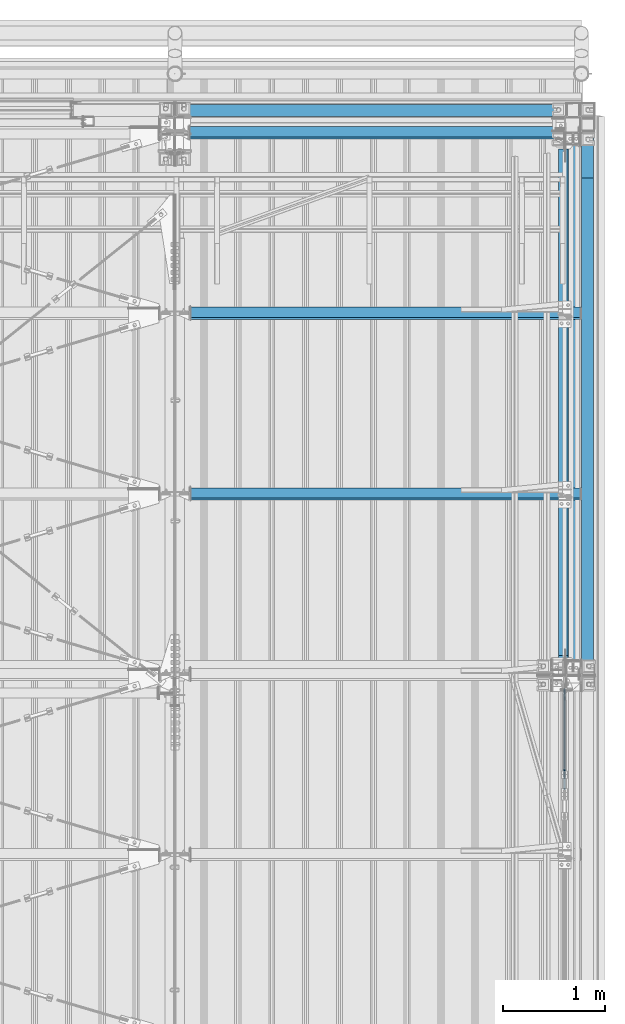
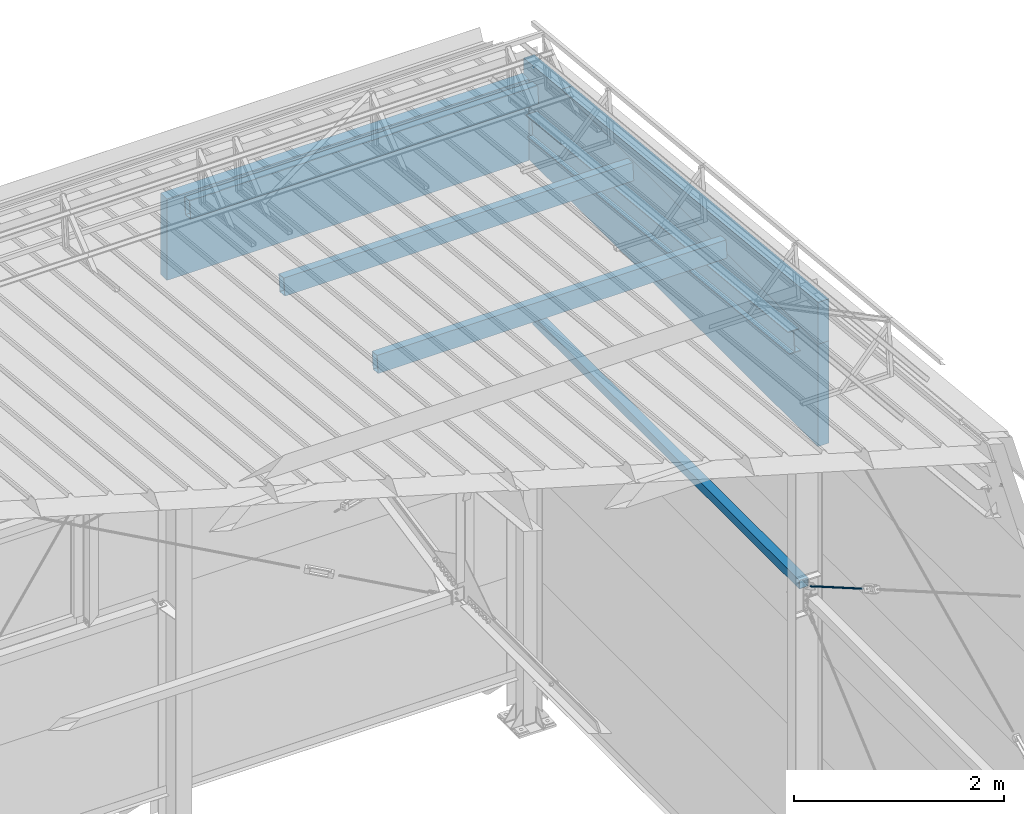
# One storey, part 289 of 709: 8 beams, 1 member, 1 opening, 9 elements without a shape of their own.
"""IFC4 building model written with IfcOpenShell, lengths in millimetres."""

from ifc_helpers import new_model, si_unit, direction, frame, origin_with_axes, place, context, subcontext, project, spatial, line, indexed_curve, outline, extrude, polygons, material, element, aggregate, save


model = new_model("IFC4")

# Units and contexts
model_context = context("Model", 3, precision=0.2, world=origin_with_axes(), true_north=direction((0.0, 1.0)))
body_context = subcontext(model_context, "Body", "Model", "MODEL_VIEW")
reference_context = subcontext(model_context, "Reference", "Model", "MODEL_VIEW")
ifc_project = project(units=[si_unit("LENGTHUNIT", "METRE", prefix="MILLI"), si_unit("AREAUNIT", "SQUARE_METRE"), si_unit("VOLUMEUNIT", "CUBIC_METRE"), si_unit("MASSUNIT", "GRAM", prefix="KILO"), si_unit("TIMEUNIT", "SECOND"), si_unit("PLANEANGLEUNIT", "RADIAN"), si_unit("SOLIDANGLEUNIT", "STERADIAN"), si_unit("THERMODYNAMICTEMPERATUREUNIT", "DEGREE_CELSIUS"), si_unit("LUMINOUSINTENSITYUNIT", "LUMEN")], contexts=[model_context])

# Site, building, storey
site_placement = place(None, origin_with_axes())
site = spatial("IfcSite", under=ifc_project, at=site_placement, CompositionType="ELEMENT")
building_placement = place(site_placement, origin_with_axes())
building = spatial("IfcBuilding", under=site, at=building_placement, Name="Undefined", CompositionType="ELEMENT")
storey_placement = place(building_placement, origin_with_axes())
storey = spatial("IfcBuildingStorey", under=building, at=storey_placement, Name="Undefined", CompositionType="ELEMENT", Elevation=0.0)

# Assembly, beam
assembly_1_placement = place(storey_placement, frame((49837.5, 21654.0, 6929.907), z_axis=(-1.0, 0.0, 0.0), x_axis=(0.0, -0.9950371902, 0.099503719)))
assembly_1 = element("IfcElementAssembly", 1, at=assembly_1_placement, inside=storey)
ifc_material_1 = material(Name="C255-4", Category="STEEL")
beam_1_placement = place(assembly_1_placement, origin_with_axes())
beam_1 = element("IfcBeam", 2, at=beam_1_placement, material=ifc_material_1, ObjectType="451", context=body_context, shape_type="Tessellation", body=[
    polygons([(-15.12818, -124.0, 62.0), (-15.12818, -116.0, 62.0), (-15.12818, -116.0, 2.5), (-15.12818, 116.0, 2.5), (-15.12818, 116.0, 62.0), (-15.12818, 124.0, 62.0), (-15.12818, 124.0, -62.0), (-15.12818, 116.0, -62.0), (-15.12818, 116.0, -2.5), (-15.12818, -116.0, -2.5), (-15.12818, -116.0, -62.0), (-15.12818, -124.0, -62.0), (4996.83432, 124.0, 62.0), (4996.83432, 124.0, -62.0), (4996.83432, 116.0, -62.0), (4996.83432, 116.0, -2.5), (4996.83432, -116.0, -2.5), (4996.83432, -116.0, -62.0), (4996.83432, -124.0, -62.0), (4996.83432, -124.0, 62.0), (4996.83432, -116.0, 62.0), (4996.83432, -116.0, 2.5), (4996.83432, 116.0, 2.5), (4996.83432, 116.0, 62.0)], [[[1, 2, 3, 4, 5, 6, 7, 8, 9, 10, 11, 12]], [[7, 6, 13, 14]], [[8, 7, 14, 15]], [[9, 8, 15, 16]], [[10, 9, 16, 17]], [[11, 10, 17, 18]], [[12, 11, 18, 19]], [[1, 12, 19, 20]], [[2, 1, 20, 21]], [[3, 2, 21, 22]], [[4, 3, 22, 23]], [[5, 4, 23, 24]], [[6, 5, 24, 13]], [[23, 22, 21, 20, 19, 18, 17, 16, 15, 14, 13, 24]]], closed=True),
])
aggregate(assembly_1, [beam_1])

# Assembly, member, voiding feature
assembly_2_placement = place(storey_placement, frame((49835.0, 15212.89749, 5439.71077), z_axis=(1.0, 0.0, 0.0), x_axis=(0.0, 0.866144648, -0.499793406)))
assembly_2 = element("IfcElementAssembly", 3, at=assembly_2_placement, inside=storey)
ifc_material_2 = material(Name="C355-5", Category="STEEL")
member_placement = place(assembly_2_placement, origin_with_axes())
member = element("IfcMember", 4, at=member_placement, material=ifc_material_2, ObjectType="515", context=body_context, shape_type="Tessellation", body=[
    polygons([(1330.0, -5.0, 8.66025), (1330.0, -7.07107, 7.07107), (1330.0, -8.66025, 5.0), (1330.0, -9.65926, 2.58819), (1330.0, -10.0, 0.0), (1330.0, -9.65926, -2.58819), (1330.0, -8.66025, -5.0), (1330.0, -7.07107, -7.07107), (1330.0, -5.0, -8.66025), (1330.0, -2.58819, -9.65926), (1330.0, 0.0, -10.0), (1330.0, 2.58819, -9.65926), (1330.0, 5.0, -8.66025), (1330.0, 7.07107, -7.07107), (1330.0, 8.66025, -5.0), (1330.0, 9.65926, -2.58819), (1330.0, 10.0, 0.0), (1330.0, 9.65926, 2.58819), (1330.0, 8.66025, 5.0), (1330.0, 7.07107, 7.07107), (1330.0, 5.0, 8.66025), (1330.0, 2.58819, 9.65926), (1330.0, 0.0, 10.0), (1330.0, -2.58819, 9.65926), (190.0, 10.0, 0.0), (190.0, 9.65926, 2.58819), (190.0, 8.66025, 5.0), (190.0, 7.07107, 7.07107), (190.0, 5.0, 8.66025), (190.0, 2.58819, 9.65926), (190.0, 0.0, 10.0), (190.0, -2.58819, 9.65926), (190.0, -5.0, 8.66025), (190.0, -7.07107, 7.07107), (190.0, -8.66025, 5.0), (190.0, -9.65926, 2.58819), (190.0, -10.0, 0.0), (190.0, -9.65926, -2.58819), (190.0, -8.66025, -5.0), (190.0, -7.07107, -7.07107), (190.0, -5.0, -8.66025), (190.0, -2.58819, -9.65926), (190.0, 0.0, -10.0), (190.0, 2.58819, -9.65926), (190.0, 5.0, -8.66025), (190.0, 7.07107, -7.07107), (190.0, 8.66025, -5.0), (190.0, 9.65926, -2.58819), (10.0, 7.36122, 4.25), (190.0, 7.36122, 4.25), (190.0, 8.21037, 2.19996), (10.0, 8.21037, 2.19996), (10.0, 6.01041, 6.01041), (190.0, 6.01041, 6.01041), (10.0, 4.25, 7.36122), (190.0, 4.25, 7.36122), (10.0, 2.19996, 8.21037), (190.0, 2.19996, 8.21037), (10.0, 0.0, 8.5), (190.0, 0.0, 8.5), (10.0, -2.19996, 8.21037), (190.0, -2.19996, 8.21037), (10.0, -4.25, 7.36122), (190.0, -4.25, 7.36122), (10.0, -6.01041, 6.01041), (190.0, -6.01041, 6.01041), (10.0, -7.36122, 4.25), (190.0, -7.36122, 4.25), (10.0, -8.21037, 2.19996), (190.0, -8.21037, 2.19996), (10.0, -8.5, 0.0), (190.0, -8.5, 0.0), (10.0, -8.21037, -2.19996), (190.0, -8.21037, -2.19996), (10.0, -7.36122, -4.25), (190.0, -7.36122, -4.25), (10.0, -6.01041, -6.01041), (190.0, -6.01041, -6.01041), (10.0, -4.25, -7.36122), (190.0, -4.25, -7.36122), (10.0, -2.19996, -8.21037), (190.0, -2.19996, -8.21037), (10.0, 0.0, -8.5), (190.0, 0.0, -8.5), (10.0, 2.19996, -8.21037), (190.0, 2.19996, -8.21037), (10.0, 4.25, -7.36122), (190.0, 4.25, -7.36122), (10.0, 6.01041, -6.01041), (190.0, 6.01041, -6.01041), (10.0, 7.36122, -4.25), (190.0, 7.36122, -4.25), (10.0, 8.21037, -2.19996), (190.0, 8.21037, -2.19996), (10.0, 8.5, 0.0), (190.0, 8.5, 0.0)], [[[1, 2, 3, 4, 5, 6, 7, 8, 9, 10, 11, 12, 13, 14, 15, 16, 17, 18, 19, 20, 21, 22, 23, 24]], [[18, 17, 25, 26]], [[19, 18, 26, 27]], [[20, 19, 27, 28]], [[21, 20, 28, 29]], [[22, 21, 29, 30]], [[23, 22, 30, 31]], [[24, 23, 31, 32]], [[1, 24, 32, 33]], [[2, 1, 33, 34]], [[3, 2, 34, 35]], [[4, 3, 35, 36]], [[5, 4, 36, 37]], [[6, 5, 37, 38]], [[7, 6, 38, 39]], [[8, 7, 39, 40]], [[9, 8, 40, 41]], [[10, 9, 41, 42]], [[11, 10, 42, 43]], [[12, 11, 43, 44]], [[13, 12, 44, 45]], [[14, 13, 45, 46]], [[15, 14, 46, 47]], [[16, 15, 47, 48]], [[17, 16, 48, 25]], [[25, 48, 47, 46, 45, 44, 43, 42, 41, 40, 39, 38, 37, 36, 35, 34, 33, 32, 31, 30, 29, 28, 27, 26], [74, 76, 78, 80, 82, 84, 86, 88, 90, 92, 94, 96, 51, 50, 54, 56, 58, 60, 62, 64, 66, 68, 70, 72]], [[49, 50, 51, 52]], [[53, 54, 50, 49]], [[55, 56, 54, 53]], [[57, 58, 56, 55]], [[59, 60, 58, 57]], [[61, 62, 60, 59]], [[63, 64, 62, 61]], [[65, 66, 64, 63]], [[67, 68, 66, 65]], [[69, 70, 68, 67]], [[71, 72, 70, 69]], [[73, 74, 72, 71]], [[75, 76, 74, 73]], [[77, 78, 76, 75]], [[79, 80, 78, 77]], [[81, 82, 80, 79]], [[83, 84, 82, 81]], [[85, 86, 84, 83]], [[87, 88, 86, 85]], [[89, 90, 88, 87]], [[91, 92, 90, 89]], [[93, 94, 92, 91]], [[95, 96, 94, 93]], [[52, 51, 96, 95]], [[91, 89, 87, 85, 83, 81, 79, 77, 75, 73, 71, 69, 67, 65, 63, 61, 59, 57, 55, 53, 49, 52, 95, 93]]], closed=True),
])
voiding_feature_placement = place(member_placement, frame((10.0, 0.0, 0.0), z_axis=(0.0, -1.0, 0.0), x_axis=(1.0, 0.0, 0.0)))
element("IfcVoidingFeature", 5, at=voiding_feature_placement, cuts=member, PredefinedType="HOLE", context=reference_context, identifier="Reference", shape_type="SolidModel", body=[
    extrude(outline(indexed_curve([(10.5, 0.0), (10.14222, 2.7176), (9.09327, 5.25), (7.42462, 7.42462), (5.25, 9.09327), (2.7176, 10.14222), (0.0, 10.5), (-2.7176, 10.14222), (-5.25, 9.09327), (-7.42462, 7.42462), (-9.09327, 5.25), (-10.14222, 2.7176), (-10.5, 0.0), (-10.14222, -2.7176), (-9.09327, -5.25), (-7.42462, -7.42462), (-5.25, -9.09327), (-2.7176, -10.14222), (0.0, -10.5), (2.7176, -10.14222), (5.25, -9.09327), (7.42462, -7.42462), (9.09327, -5.25), (10.14222, -2.7176)], segments=[line(1, 2, 3, 4, 5, 6, 7, 8, 9, 10, 11, 12, 13, 14, 15, 16, 17, 18, 19, 20, 21, 22, 23, 24, 1)])), frame((0.0, 0.0, 0.0), z_axis=(-1.0, 0.0, 0.0), x_axis=(0.0, 0.0, 1.0)), (0.0, 0.0, -1.0), 180.0),
])
aggregate(assembly_2, [member])

# Assembly, beam
assembly_3_placement = place(storey_placement, frame((49920.0, 16500.0, 4610.0), z_axis=(0.0, 0.0, -1.0), x_axis=(0.0, 1.0, 0.0)))
assembly_3 = element("IfcElementAssembly", 6, at=assembly_3_placement, inside=storey)
ifc_material_3 = material(Name="C355", Category="STEEL")
beam_2_placement = place(assembly_3_placement, origin_with_axes())
beam_2 = element("IfcBeam", 7, at=beam_2_placement, material=ifc_material_3, ObjectType="494", context=body_context, shape_type="Tessellation", body=[
    polygons([(142.5, -50.0, 50.0), (142.5, -50.0, -50.0), (5222.0, -50.0, -50.0), (5222.0, -50.0, 50.0), (142.5, 50.0, 50.0), (5222.0, 50.0, 50.0), (142.5, 50.0, -50.0), (5222.0, 50.0, -50.0), (142.5, -47.0, 47.0), (142.5, 47.0, 47.0), (5222.0, 47.0, 47.0), (5222.0, -47.0, 47.0), (142.5, -47.0, -47.0), (5222.0, -47.0, -47.0), (142.5, 47.0, -47.0), (5222.0, 47.0, -47.0)], [[[1, 2, 3, 4]], [[5, 1, 4, 6]], [[7, 5, 6, 8]], [[2, 7, 8, 3]], [[1, 5, 7, 2], [15, 10, 9, 13]], [[9, 10, 11, 12]], [[13, 9, 12, 14]], [[15, 13, 14, 16]], [[10, 15, 16, 11]], [[3, 8, 6, 4], [14, 12, 11, 16]]], closed=True),
])
aggregate(assembly_3, [beam_2])

assembly_4_placement = place(storey_placement, frame((50000.0, 18286.65012, 7499.7991), z_axis=(0.0, -0.9950371902, 0.099503719), x_axis=(-1.0, 0.0, 0.0)))
assembly_4 = element("IfcElementAssembly", 8, at=assembly_4_placement, inside=storey)
beam_3_placement = place(assembly_4_placement, origin_with_axes())
beam_3 = element("IfcBeam", 9, at=beam_3_placement, material=ifc_material_3, ObjectType="563", context=body_context, shape_type="Tessellation", body=[
    polygons([(3845.0, 100.0, 50.0), (3845.0, 100.0, -50.0), (8.0, 100.0, -50.0), (8.0, 100.0, 50.0), (3845.0, -100.0, 50.0), (8.0, -100.0, 50.0), (3845.0, -100.0, -50.0), (8.0, -100.0, -50.0), (3845.0, 96.0, -46.0), (3845.0, 96.0, 46.0), (8.0, 96.0, 46.0), (8.0, 96.0, -46.0), (3845.0, -96.0, -46.0), (8.0, -96.0, -46.0), (3845.0, -96.0, 46.0), (8.0, -96.0, 46.0)], [[[1, 2, 3, 4]], [[5, 1, 4, 6]], [[7, 5, 6, 8]], [[2, 7, 8, 3]], [[1, 5, 7, 2], [10, 9, 13, 15]], [[9, 10, 11, 12]], [[13, 9, 12, 14]], [[15, 13, 14, 16]], [[10, 15, 16, 11]], [[8, 6, 4, 3], [14, 12, 11, 16]]], closed=True),
])
aggregate(assembly_4, [beam_3])

assembly_5_placement = place(storey_placement, frame((50000.0, 20063.34988, 7322.12913), z_axis=(0.0, -0.9950371902, 0.099503719), x_axis=(-1.0, 0.0, 0.0)))
assembly_5 = element("IfcElementAssembly", 10, at=assembly_5_placement, inside=storey)
beam_4_placement = place(assembly_5_placement, origin_with_axes())
beam_4 = element("IfcBeam", 11, at=beam_4_placement, material=ifc_material_3, ObjectType="563", context=body_context, shape_type="Tessellation", body=[
    polygons([(3845.0, 100.0, 50.0), (3845.0, 100.0, -50.0), (8.0, 100.0, -50.0), (8.0, 100.0, 50.0), (3845.0, -100.0, 50.0), (8.0, -100.0, 50.0), (3845.0, -100.0, -50.0), (8.0, -100.0, -50.0), (3845.0, 96.0, -46.0), (3845.0, 96.0, 46.0), (8.0, 96.0, 46.0), (8.0, 96.0, -46.0), (3845.0, -96.0, -46.0), (8.0, -96.0, -46.0), (3845.0, -96.0, 46.0), (8.0, -96.0, 46.0)], [[[1, 2, 3, 4]], [[5, 1, 4, 6]], [[7, 5, 6, 8]], [[2, 7, 8, 3]], [[1, 5, 7, 2], [10, 9, 13, 15]], [[9, 10, 11, 12]], [[13, 9, 12, 14]], [[15, 13, 14, 16]], [[10, 15, 16, 11]], [[8, 6, 4, 3], [14, 12, 11, 16]]], closed=True),
])
aggregate(assembly_5, [beam_4])

assembly_6_placement = place(storey_placement, frame((50000.0, 21840.04963, 7144.45915), z_axis=(0.0, -0.9950371902, 0.099503719), x_axis=(-1.0, 0.0, 0.0)))
assembly_6 = element("IfcElementAssembly", 12, at=assembly_6_placement, inside=storey)
beam_5_placement = place(assembly_6_placement, origin_with_axes())
beam_5 = element("IfcBeam", 13, at=beam_5_placement, material=ifc_material_3, ObjectType="562", context=body_context, shape_type="Tessellation", body=[
    polygons([(3855.0, 100.0, 50.0), (3855.0, 100.0, -50.0), (28.0, 100.0, -50.0), (28.0, 100.0, 50.0), (3855.0, -100.0, 50.0), (28.0, -100.0, 50.0), (3855.0, -100.0, -50.0), (28.0, -100.0, -50.0), (3855.0, 96.0, -46.0), (3855.0, 96.0, 46.0), (28.0, 96.0, 46.0), (28.0, 96.0, -46.0), (3855.0, -96.0, -46.0), (28.0, -96.0, -46.0), (3855.0, -96.0, 46.0), (28.0, -96.0, 46.0)], [[[1, 2, 3, 4]], [[5, 1, 4, 6]], [[7, 5, 6, 8]], [[2, 7, 8, 3]], [[1, 5, 7, 2], [10, 9, 13, 15]], [[9, 10, 11, 12]], [[13, 9, 12, 14]], [[15, 13, 14, 16]], [[10, 15, 16, 11]], [[8, 6, 4, 3], [14, 12, 11, 16]]], closed=True),
])
aggregate(assembly_6, [beam_5])

assembly_7_placement = place(storey_placement, frame((46010.0, 22060.0, 6845.0), z_axis=(0.0, 0.0, -1.0), x_axis=(1.0, 0.0, 0.0)))
assembly_7 = element("IfcElementAssembly", 14, at=assembly_7_placement, inside=storey)
ifc_material_4 = material(Name="Insulation", Category="Insulation")
beam_6_placement = place(assembly_7_placement, origin_with_axes())
beam_6 = element("IfcBeam", 15, at=beam_6_placement, material=ifc_material_4, ObjectType="P-119", context=body_context, shape_type="Tessellation", body=[
    polygons([(0.0, 60.0, 595.0), (0.0, -60.0, 595.0), (3980.0, -60.0, 595.0), (3980.0, 60.0, 595.0), (3980.0, 60.0, -351.923), (0.0, 60.0, -351.923), (0.0, -60.0, -351.923), (3980.0, -60.0, -351.923)], [[[1, 2, 3, 4]], [[1, 4, 5, 6]], [[2, 1, 6, 7]], [[3, 2, 7, 8]], [[4, 3, 8, 5]], [[7, 6, 5, 8]]], closed=True),
])
aggregate(assembly_7, [beam_6])

assembly_8_placement = place(storey_placement, frame((50060.0, 16510.0, 6845.0), z_axis=(0.0, 0.0, -1.0), x_axis=(0.0, 1.0, 0.0)))
assembly_8 = element("IfcElementAssembly", 16, at=assembly_8_placement, inside=storey)
beam_7_placement = place(assembly_8_placement, origin_with_axes())
beam_7 = element("IfcBeam", 17, at=beam_7_placement, material=ifc_material_4, ObjectType="P-131", context=body_context, shape_type="Tessellation", body=[
    polygons([(0.0, -60.0, 595.0), (0.0, 60.0, 595.0), (0.0, 60.0, -595.0), (0.0, -60.0, -595.0), (5610.0, -60.0, 595.0), (5610.0, 60.0, 595.0), (5610.0, 60.0, -522.671), (4886.71, 60.0, -595.0), (4886.71, -60.0, -595.0), (5610.0, -60.0, -522.671)], [[[1, 2, 3, 4]], [[2, 1, 5, 6]], [[3, 2, 6, 7, 8]], [[4, 3, 8, 9]], [[5, 1, 4, 9, 10]], [[6, 5, 10, 7]], [[9, 8, 7, 10]]], closed=True),
])
aggregate(assembly_8, [beam_7])

assembly_9_placement = place(storey_placement, frame((50060.0, 16510.0, 8035.0), z_axis=(0.0, 0.0, -1.0), x_axis=(0.0, 1.0, 0.0)))
assembly_9 = element("IfcElementAssembly", 18, at=assembly_9_placement, inside=storey)
beam_8_placement = place(assembly_9_placement, origin_with_axes())
beam_8 = element("IfcBeam", 19, at=beam_8_placement, material=ifc_material_4, ObjectType="P-132", context=body_context, shape_type="Tessellation", body=[
    polygons([(0.0, 60.0, 595.0), (4886.71, 60.0, 595.0), (0.0, 60.0, 106.329), (0.0, -60.0, 595.0), (0.0, -60.0, 106.329), (4886.71, -60.0, 595.0)], [[[1, 2, 3]], [[4, 1, 3, 5]], [[4, 5, 6]], [[1, 4, 6, 2]], [[5, 3, 2, 6]]], closed=True),
])
aggregate(assembly_9, [beam_8])

save(model, "model.ifc")
